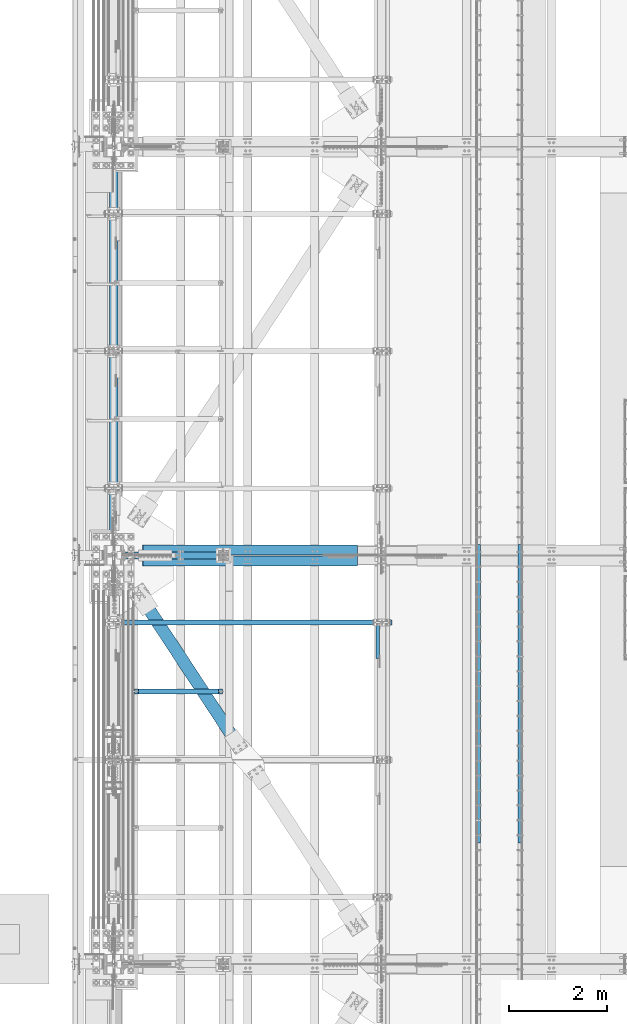
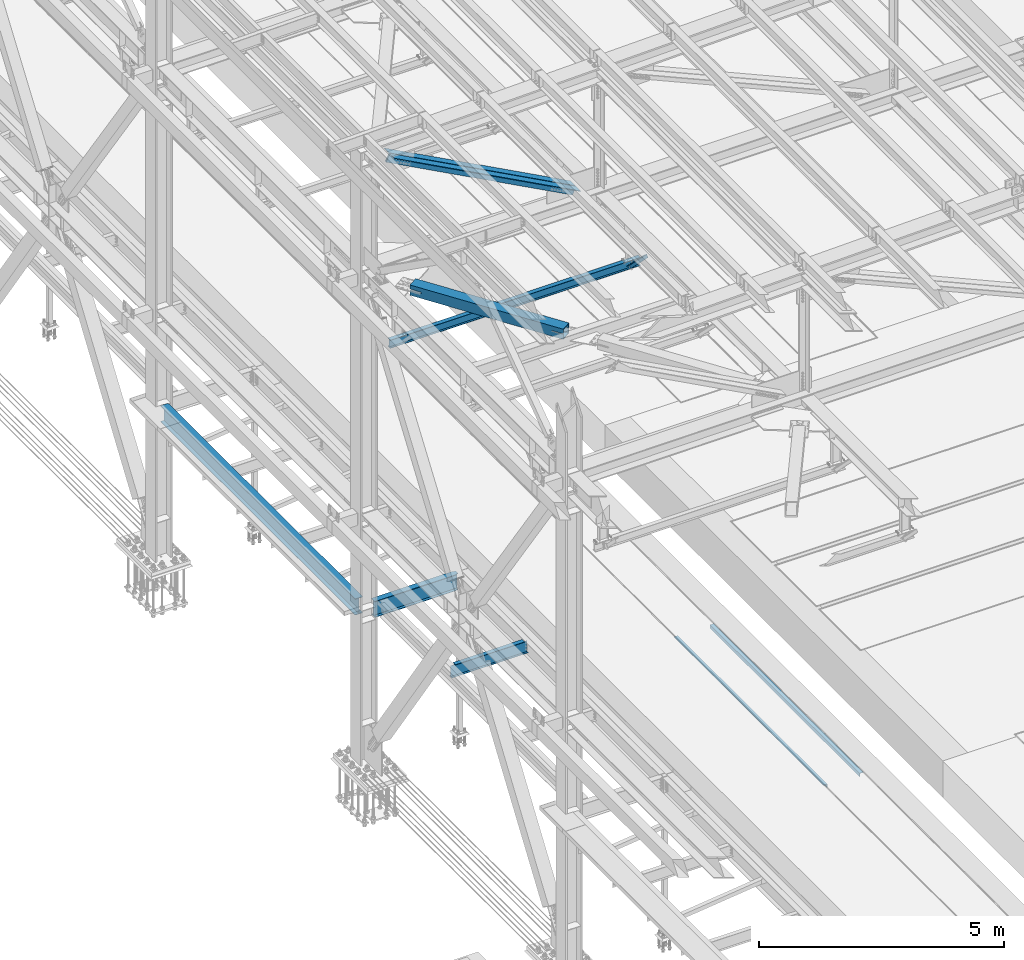
# One storey, part 1819 of 3843: 7 beams, 3 members, 10 elements without a shape of their own.
"""IFC2X3 building model written with IfcOpenShell, lengths in millimetres."""

from ifc_helpers import new_model, si_unit, frame, origin_with_axes, place, context, subcontext, project, spatial, faceted_brep, material, type_object, element, aggregate, save


model = new_model("IFC2X3")

# Units and contexts
model_context = context("Model", 3, precision=1e-05, world=origin_with_axes())
body_context = subcontext(model_context, "Body", "Model", "MODEL_VIEW")
ifc_project = project(units=[si_unit("LENGTHUNIT", "METRE", prefix="MILLI"), si_unit("AREAUNIT", "SQUARE_METRE"), si_unit("VOLUMEUNIT", "CUBIC_METRE"), si_unit("MASSUNIT", "GRAM", prefix="KILO"), si_unit("TIMEUNIT", "SECOND"), si_unit("PLANEANGLEUNIT", "RADIAN"), si_unit("SOLIDANGLEUNIT", "STERADIAN"), si_unit("THERMODYNAMICTEMPERATUREUNIT", "DEGREE_CELSIUS"), si_unit("LUMINOUSINTENSITYUNIT", "LUMEN")], contexts=[model_context])

# Site, building, storey
site_placement = place(None, origin_with_axes())
site = spatial("IfcSite", under=ifc_project, at=site_placement, CompositionType="ELEMENT")
building_placement = place(site_placement, origin_with_axes())
building = spatial("IfcBuilding", under=site, at=building_placement, Name="Undefined", CompositionType="ELEMENT")
storey_placement = place(building_placement, origin_with_axes())
storey = spatial("IfcBuildingStorey", under=building, at=storey_placement, Name="Undefined", CompositionType="ELEMENT", Elevation=0.0)

# Assembly, beam
assembly_1_placement = place(storey_placement, origin_with_axes())
assembly_1 = element("IfcElementAssembly", 1, at=assembly_1_placement, inside=storey, Name="EMBED_ANGLE", AssemblyPlace="NOTDEFINED", PredefinedType="RIGID_FRAME")
ifc_material_1 = material(Name="STEEL/A36")
beam_type_1 = type_object("IfcBeamType", Name="L3-1/2X3-1/2X5/16", PredefinedType="NOTDEFINED")
beam_1_placement = place(assembly_1_placement, frame((44887.896, 59134.375, 30419.675), z_axis=(0.0, 0.0, -1.0), x_axis=(0.0, -1.0, 0.0)))
beam_1 = element("IfcBeam", 2, at=beam_1_placement, type_object=beam_type_1, material=ifc_material_1, Name="EMBED_ANGLE", ObjectType="L3-1/2X3-1/2X5/16", context=body_context, shape_type="Brep", body=[
    faceted_brep([(-3.63797880709171e-12, 44.4499999999971, -44.4500000000007), (-3.63797880709171e-12, 44.4499999999971, 44.4500000000007), (6096.0, 44.4499999999971, 44.4500000000007), (6096.0, 44.4499999999971, -44.4500000000007), (-3.63797880709171e-12, 36.5124999999971, 44.4500000000007), (6096.0, 36.5124999999971, 44.4500000000007), (-3.63797880709171e-12, 36.5124999999971, -36.5125000000007), (6096.0, 36.5124999999971, -36.5125000000007), (3.63797880709171e-12, -44.4499999999971, -36.5125000000007), (6096.0, -44.4499999999971, -36.5125000000007), (3.63797880709171e-12, -44.4499999999971, -44.4500000000007), (6096.0, -44.4499999999971, -44.4500000000007)], [[[0, 1, 2, 3]], [[1, 4, 5, 2]], [[4, 6, 7, 5]], [[6, 8, 9, 7]], [[8, 10, 11, 9]], [[10, 0, 3, 11]], [[5, 7, 9, 11, 3, 2]], [[10, 8, 6, 4, 1, 0]]]),
])
aggregate(assembly_1, [beam_1])

assembly_2_placement = place(storey_placement, origin_with_axes())
assembly_2 = element("IfcElementAssembly", 3, at=assembly_2_placement, inside=storey, Name="EMBED_ANGLE", AssemblyPlace="NOTDEFINED", PredefinedType="RIGID_FRAME")
beam_2_placement = place(assembly_2_placement, frame((44036.996, 53038.375, 30419.675), z_axis=(0.0, 0.0, -1.0), x_axis=(0.0, 1.0, 0.0)))
beam_2 = element("IfcBeam", 4, at=beam_2_placement, type_object=beam_type_1, material=ifc_material_1, Name="EMBED_ANGLE", ObjectType="L3-1/2X3-1/2X5/16", context=body_context, shape_type="Brep", body=[
    faceted_brep([(-3.63797880709171e-12, 44.4499999999971, -44.4500000000007), (-3.63797880709171e-12, 44.4499999999971, 44.4500000000007), (6096.0, 44.4499999999971, 44.4500000000007), (6096.0, 44.4499999999971, -44.4500000000007), (-3.63797880709171e-12, 36.5124999999971, 44.4500000000007), (6096.0, 36.5124999999971, 44.4500000000007), (-3.63797880709171e-12, 36.5124999999971, -36.5125000000007), (6096.0, 36.5124999999971, -36.5125000000007), (3.63797880709171e-12, -44.4499999999971, -36.5125000000007), (6096.0, -44.4499999999971, -36.5125000000007), (3.63797880709171e-12, -44.4499999999971, -44.4500000000007), (6096.0, -44.4499999999971, -44.4500000000007)], [[[0, 1, 2, 3]], [[1, 4, 5, 2]], [[4, 6, 7, 5]], [[6, 8, 9, 7]], [[8, 10, 11, 9]], [[10, 0, 3, 11]], [[5, 7, 9, 11, 3, 2]], [[10, 8, 6, 4, 1, 0]]]),
])
aggregate(assembly_2, [beam_2])

# Assembly, member
assembly_3_placement = place(storey_placement, origin_with_axes())
assembly_3 = element("IfcElementAssembly", 5, at=assembly_3_placement, inside=storey, Name="ANGLE", AssemblyPlace="NOTDEFINED", PredefinedType="RIGID_FRAME")
ifc_material_2 = material(Name="STEEL/A572-50")
member_type_1 = type_object("IfcMemberType", Name="L3X3X1/4", PredefinedType="NOTDEFINED")
member_1_placement = place(assembly_3_placement, frame((41973.5, 56532.0689186757, 42312.0310813243), z_axis=(0.0, -0.707106781186548, -0.707106781186548), x_axis=(5.70000238222118e-08, 0.707106781186546, -0.707106781186546)))
member_1 = element("IfcMember", 6, at=member_1_placement, type_object=member_type_1, material=ifc_material_2, Name="ANGLE", ObjectType="L3X3X1/4", context=body_context, shape_type="Brep", body=[
    faceted_brep([(1347.66111465942, -38.0999999999985, -31.7499999999272), (1347.66111465942, -38.0999999999985, -38.099999999904), (1347.66111465942, 38.0999999999985, -38.099999999904), (1347.66111465941, 38.0999999999985, 38.0999999999185), (1347.66111465941, 31.75, 38.0999999999185), (1347.66111465942, 31.75, -31.7499999999272), (357.061114659338, 31.75, 38.0999999999185), (357.061114659338, 31.75, -31.7499999999127), (357.061114659338, -38.0999999999985, -31.7499999999127), (357.061114659338, -38.0999999999985, -38.099999999904), (357.061114659338, 38.0999999999985, -38.099999999904), (357.061114659338, 38.0999999999985, 38.0999999999185)], [[[0, 1, 2, 3, 4, 5]], [[5, 4, 6, 7]], [[0, 5, 7, 8]], [[1, 0, 8, 9]], [[2, 1, 9, 10]], [[3, 2, 10, 11]], [[4, 3, 11, 6]], [[10, 9, 8, 7, 6, 11]]]),
])
aggregate(assembly_3, [member_1])

# Assembly, beam
assembly_4_placement = place(storey_placement, origin_with_axes())
assembly_4 = element("IfcElementAssembly", 7, at=assembly_4_placement, inside=storey, Name="BEAM", AssemblyPlace="NOTDEFINED", PredefinedType="RIGID_FRAME")
ifc_material_3 = material(Name="STEEL/A992")
beam_type_2 = type_object("IfcBeamType", Name="W8X13", PredefinedType="NOTDEFINED")
beam_3_placement = place(assembly_4_placement, frame((36372.8, 57543.7, 41402.0), z_axis=(0.0, 0.0, 1.0), x_axis=(1.0, 0.0, 0.0)))
beam_3 = element("IfcBeam", 8, at=beam_3_placement, type_object=beam_type_2, material=ifc_material_3, Name="BEAM", ObjectType="W8X13", context=body_context, shape_type="Brep", body=[
    faceted_brep([(0.0, 50.7999999999993, -101.599999999999), (0.0, 50.7999999999993, -95.25), (5892.8, 50.7999999999993, -95.25), (5892.8, 50.7999999999993, -101.599999999999), (0.0, 3.17499999999927, -95.25), (5892.8, 3.17499999999927, -95.25), (-2.44140610448085e-05, 3.17500000000291, 95.2499999999927), (5892.8, 3.17499999999927, 95.25), (0.0, 50.7999999999993, 95.25), (5892.8, 50.7999999999993, 95.25), (0.0, 50.7999999999993, 101.599999999999), (5892.8, 50.7999999999993, 101.599999999999), (0.0, -50.7999999999993, 101.599999999999), (5892.8, -50.7999999999993, 101.599999999999), (0.0, -50.7999999999993, 95.25), (5892.8, -50.7999999999993, 95.25), (0.0, -3.17499999999927, 95.25), (5892.8, -3.17499999999927, 95.25), (0.0, -3.17499999999927, -95.25), (5892.8, -3.17499999999927, -95.25), (0.0, -50.7999999999993, -95.25), (5892.8, -50.7999999999993, -95.25), (0.0, -50.7999999999993, -101.599999999999), (5892.8, -50.7999999999993, -101.599999999999)], [[[0, 1, 2, 3]], [[1, 4, 5, 2]], [[4, 6, 7, 5]], [[6, 8, 9, 7]], [[8, 10, 11, 9]], [[10, 12, 13, 11]], [[12, 14, 15, 13]], [[14, 16, 17, 15]], [[16, 18, 19, 17]], [[18, 20, 21, 19]], [[20, 22, 23, 21]], [[22, 0, 3, 23]], [[5, 7, 9, 11, 13, 15, 17, 19, 21, 23, 3, 2]], [[22, 20, 18, 16, 14, 12, 10, 8, 6, 4, 1, 0]]]),
])
aggregate(assembly_4, [beam_3])

# Assembly, member
assembly_5_placement = place(storey_placement, origin_with_axes())
assembly_5 = element("IfcElementAssembly", 9, at=assembly_5_placement, inside=storey, Name="ANGLE", AssemblyPlace="NOTDEFINED", PredefinedType="RIGID_FRAME")
member_type_2 = type_object("IfcMemberType", Name="L8X8X1/2", PredefinedType="NOTDEFINED")
member_2_placement = place(assembly_5_placement, frame((36576.0, 59026.425, 45221.4518084381), z_axis=(-0.472785194825838, 0.0, -0.8811777116754), x_axis=(0.8811777116754, 0.0, -0.472785194825839)))
member_2 = element("IfcMember", 10, at=member_2_placement, type_object=member_type_2, material=ifc_material_2, Name="ANGLE", ObjectType="L8X8X1/2", context=body_context, shape_type="Brep", body=[
    faceted_brep([(625.176479064765, 101.599999999999, -101.600000001054), (625.176479064772, 101.599999999999, 101.599999999627), (5601.4263412947, 101.599999999999, 101.599999993981), (5601.42634129471, 101.599999999999, -101.600000006707), (625.176479064772, 88.9000000000015, 101.599999999627), (5601.4263412947, 88.9000000000015, 101.599999993981), (625.176479064769, 88.9000000000015, -88.9000000010128), (5601.42634129471, 88.9000000000015, -88.9000000066735), (625.176479064769, -101.599999999999, -88.9000000010128), (5601.42634129471, -101.599999999999, -88.9000000066735), (625.176479064765, -101.599999999999, -101.600000001054), (5601.42634129471, -101.599999999999, -101.600000006707)], [[[0, 1, 2, 3]], [[1, 4, 5, 2]], [[4, 6, 7, 5]], [[6, 8, 9, 7]], [[8, 10, 11, 9]], [[10, 0, 3, 11]], [[5, 7, 9, 11, 3, 2]], [[10, 8, 6, 4, 1, 0]]]),
])
aggregate(assembly_5, [member_2])

assembly_6_placement = place(storey_placement, origin_with_axes())
assembly_6 = element("IfcElementAssembly", 11, at=assembly_6_placement, inside=storey, Name="ANGLE", AssemblyPlace="NOTDEFINED", PredefinedType="RIGID_FRAME")
member_3_placement = place(assembly_6_placement, frame((42062.3999992073, 58804.175, 42277.790551132), z_axis=(-0.472785194825838, 0.0, -0.8811777116754), x_axis=(-0.8811777116754, 0.0, 0.472785194825838)))
member_3 = element("IfcMember", 12, at=member_3_placement, type_object=member_type_2, material=ifc_material_2, Name="ANGLE", ObjectType="L8X8X1/2", context=body_context, shape_type="Brep", body=[
    faceted_brep([(624.786516421329, 101.599999999999, -101.599999999627), (624.786516421325, 101.599999999999, 101.600000001054), (5601.03637865126, 101.599999999999, 101.600000006707), (5601.03637865126, 101.599999999999, -101.599999993981), (624.786516421325, 88.9000000000015, 101.600000001054), (5601.03637865126, 88.9000000000015, 101.600000006707), (624.786516421325, 88.9000000000015, -88.899999999594), (5601.03637865126, 88.9000000000015, -88.8999999939406), (624.786516421325, -101.599999999999, -88.899999999594), (5601.03637865126, -101.599999999999, -88.8999999939406), (624.786516421329, -101.599999999999, -101.599999999627), (5601.03637865126, -101.599999999999, -101.599999993981)], [[[0, 1, 2, 3]], [[1, 4, 5, 2]], [[4, 6, 7, 5]], [[6, 8, 9, 7]], [[8, 10, 11, 9]], [[10, 0, 3, 11]], [[5, 7, 9, 11, 3, 2]], [[10, 8, 6, 4, 1, 0]]]),
])
aggregate(assembly_6, [member_3])

# Assembly, beam
assembly_7_placement = place(storey_placement, origin_with_axes())
assembly_7 = element("IfcElementAssembly", 13, at=assembly_7_placement, inside=storey, AssemblyPlace="NOTDEFINED", PredefinedType="RIGID_FRAME")
ifc_material_4 = material()
beam_type_3 = type_object("IfcBeamType", Name="HSS10X10X3/4", PredefinedType="NOTDEFINED")
beam_4_placement = place(assembly_7_placement, frame((36576.0, 58915.3, 42246.55), z_axis=(0.835938629021657, 0.548822930014219, 0.0), x_axis=(0.548822930014218, -0.835938629021658, 0.0)))
beam_4 = element("IfcBeam", 14, at=beam_4_placement, type_object=beam_type_3, material=ifc_material_4, ObjectType="HSS10X10X3/4", context=body_context, shape_type="Brep", body=[
    faceted_brep([(4607.8393605934, 1.58750000000146, 127.000000003842), (4355.42686058164, 1.58750000000146, 127.000000003667), (4355.42686058166, 1.58750000000146, 107.950000003577), (4607.83936059341, 1.58750000000146, 107.950000003759), (4352.38931083721, 0.983293789307936, 127.000000003667), (4352.38931083722, 0.983293789307936, 107.950000003577), (4349.8142005059, -0.737339924329717, 127.00000000366), (4349.81420050591, -0.737339924329717, 107.950000003577), (4348.09356679223, -3.31245025560202, 127.00000000366), (4348.09356679225, -3.31245025560202, 107.95000000357), (4347.48936058155, -6.34999999999854, 127.000000003653), (4347.48936058156, -6.34999999999854, 107.950000003577), (4348.09356679223, -9.38754974439507, 127.00000000366), (4348.09356679225, -9.38754974439507, 107.95000000357), (4349.8142005059, -11.9626600756674, 127.00000000366), (4349.81420050591, -11.9626600756674, 107.950000003577), (4352.38931083721, -13.683293789305, 127.000000003667), (4352.38931083722, -13.683293789305, 107.950000003577), (4355.42686058164, -14.2874999999985, 127.000000003667), (4355.42686058166, -14.2874999999985, 107.950000003577), (4607.8393605934, -14.2874999999985, 127.000000003842), (4607.83936059341, -14.2874999999985, 107.950000003759), (4607.83936059341, 1.58750000000146, -107.949999997174), (4355.42686058181, 1.58750000000146, -107.949999997363), (4355.42686058182, 1.58750000000146, -126.999999997439), (4607.83936059341, 1.58750000000146, -126.999999997264), (4352.38931083737, 0.983293789307936, -107.949999997356), (4352.38931083739, 0.983293789307936, -126.999999997439), (4349.81420050607, -0.737339924329717, -107.949999997363), (4349.81420050608, -0.737339924329717, -126.999999997439), (4348.0935667924, -3.31245025560202, -107.949999997363), (4348.09356679242, -3.31245025560202, -126.999999997439), (4347.48936058171, -6.34999999999854, -107.949999997363), (4347.48936058172, -6.34999999999854, -126.999999997453), (4348.0935667924, -9.38754974439507, -107.949999997363), (4348.09356679242, -9.38754974439507, -126.999999997439), (4349.81420050607, -11.9626600756674, -107.949999997363), (4349.81420050608, -11.9626600756674, -126.999999997439), (4352.38931083737, -13.683293789305, -107.949999997356), (4352.38931083739, -13.683293789305, -126.999999997439), (4355.42686058181, -14.2874999999985, -107.949999997363), (4355.42686058182, -14.2874999999985, -126.999999997439), (4607.83936059341, -14.2874999999985, -107.949999997174), (4607.83936059341, -14.2874999999985, -126.999999997264), (1109.41820844431, 107.949999999997, 107.95000000127), (1109.41820844432, 107.949999999997, -107.949999999662), (4607.83936059341, 107.949999999997, -107.949999997174), (4607.83936059341, 107.949999999997, 107.950000003759), (4607.83936059341, -107.949999999997, 107.950000003759), (1109.41820844431, -107.949999999997, 107.95000000127), (1109.41820844431, -26.9875000002503, 107.95000000127), (1361.83070807912, -26.9875000002503, 107.950000001452), (1367.29829776509, -25.8999287919651, 107.950000001452), (1371.9334964852, -22.8027880247246, 107.95000000146), (1375.03063725248, -18.1675893046777, 107.950000001452), (1376.11820846077, -12.6999996187806, 107.95000000146), (1375.03063725248, -7.23241069582582, 107.950000001452), (1371.9334964852, -2.59721197577892, 107.95000000146), (1367.29829776509, 0.499928791461571, 107.950000001452), (1361.83070807912, 1.5874999997468, 107.950000001452), (1109.41820844431, 1.5874999997468, 107.95000000127), (1109.41820844432, -107.949999999997, -107.949999999662), (4607.83936059341, -107.949999999997, -107.949999997174), (1109.41820844432, 1.5874999997468, -107.949999999662), (1361.83070807928, 1.5874999997468, -107.949999999488), (1367.29829776525, 0.499928791461571, -107.949999999488), (1371.93349648534, -2.59721197577892, -107.949999999473), (1375.03063725263, -7.23241069582582, -107.94999999948), (1376.11820846093, -12.6999996187806, -107.949999999473), (1375.03063725263, -18.1675893046777, -107.94999999948), (1371.93349648534, -22.8027880247246, -107.949999999473), (1367.29829776525, -25.8999287919651, -107.949999999488), (1361.83070807928, -26.9875000002503, -107.949999999488), (1109.41820844432, -26.9875000002503, -107.949999999662), (1109.41820844431, 1.5874999997468, -126.999999999753), (1361.83070807929, 1.5874999997468, -126.999999999571), (1367.29829776526, 0.499928791461571, -126.999999999563), (1371.93349648536, -2.59721197577892, -126.999999999563), (1375.03063725264, -7.23241069582582, -126.999999999563), (1376.11820846094, -12.6999996187806, -126.999999999563), (1375.03063725264, -18.1675893046777, -126.999999999563), (1371.93349648536, -22.8027880247246, -126.999999999563), (1367.29829776526, -25.8999287919651, -126.999999999563), (1361.83070807929, -26.9875000002503, -126.999999999571), (1109.41820844431, -26.9875000002503, -126.999999999753), (1109.41820844431, -127.0, -126.999999999753), (1109.41820844431, -127.0, 127.000000001353), (1109.41820844431, -26.9875000002503, 127.000000001353), (1361.83070807911, -26.9875000002503, 127.000000001528), (1367.29829776508, -25.8999287919651, 127.000000001543), (1371.93349648518, -22.8027880247246, 127.000000001543), (1375.03063725246, -18.1675893046777, 127.000000001543), (1376.11820846076, -12.6999996187806, 127.000000001543), (1375.03063725246, -7.23241069582582, 127.000000001543), (1371.93349648518, -2.59721197577892, 127.000000001543), (1367.29829776508, 0.499928791461571, 127.000000001543), (1361.83070807911, 1.5874999997468, 127.000000001528), (1109.41820844431, 1.5874999997468, 127.000000001353), (1109.41820844431, 127.0, 127.000000001353), (1109.41820844431, 127.0, -126.999999999753), (4607.8393605934, 127.0, 127.000000003842), (4607.83936059341, 127.0, -126.999999997264), (4607.83936059341, -127.0, -126.999999997264), (4607.8393605934, -127.0, 127.000000003842)], [[[0, 1, 2, 3]], [[4, 5, 2, 1]], [[6, 7, 5, 4]], [[8, 9, 7, 6]], [[10, 11, 9, 8]], [[12, 13, 11, 10]], [[14, 15, 13, 12]], [[16, 17, 15, 14]], [[18, 19, 17, 16]], [[20, 21, 19, 18]], [[22, 23, 24, 25]], [[26, 27, 24, 23]], [[28, 29, 27, 26]], [[30, 31, 29, 28]], [[32, 33, 31, 30]], [[34, 35, 33, 32]], [[36, 37, 35, 34]], [[38, 39, 37, 36]], [[40, 41, 39, 38]], [[42, 43, 41, 40]], [[44, 45, 46, 47]], [[48, 49, 50, 51, 52, 53, 54, 55, 56, 57, 58, 59, 60, 44, 47, 3, 2, 5, 7, 9, 11, 13, 15, 17, 19, 21]], [[61, 49, 48, 62]], [[38, 36, 34, 32, 30, 28, 26, 23, 22, 46, 45, 63, 64, 65, 66, 67, 68, 69, 70, 71, 72, 73, 61, 62, 42, 40]], [[63, 74, 75, 64]], [[64, 75, 76, 65]], [[65, 76, 77, 66]], [[66, 77, 78, 67]], [[67, 78, 79, 68]], [[68, 79, 80, 69]], [[69, 80, 81, 70]], [[70, 81, 82, 71]], [[71, 82, 83, 72]], [[72, 83, 84, 73]], [[49, 61, 73, 84, 85, 86, 87, 50]], [[88, 51, 50, 87]], [[89, 52, 51, 88]], [[90, 53, 52, 89]], [[91, 54, 53, 90]], [[92, 55, 54, 91]], [[93, 56, 55, 92]], [[94, 57, 56, 93]], [[95, 58, 57, 94]], [[96, 59, 58, 95]], [[97, 60, 59, 96]], [[98, 99, 74, 63, 45, 44, 60, 97]], [[99, 98, 100, 101]], [[47, 46, 22, 25, 101, 100, 0, 3]], [[102, 85, 84, 83, 82, 81, 80, 79, 78, 77, 76, 75, 74, 99, 101, 25, 24, 27, 29, 31, 33, 35, 37, 39, 41, 43]], [[86, 85, 102, 103]], [[16, 14, 12, 10, 8, 6, 4, 1, 0, 100, 98, 97, 96, 95, 94, 93, 92, 91, 90, 89, 88, 87, 86, 103, 20, 18]], [[103, 102, 43, 42, 62, 48, 21, 20]]]),
])
aggregate(assembly_7, [beam_4])

assembly_8_placement = place(storey_placement, origin_with_axes())
assembly_8 = element("IfcElementAssembly", 15, at=assembly_8_placement, inside=storey, Name="BEAM", AssemblyPlace="NOTDEFINED", PredefinedType="RIGID_FRAME")
beam_type_4 = type_object("IfcBeamType", Name="W16X40", PredefinedType="NOTDEFINED")
beam_5_placement = place(assembly_8_placement, frame((36576.0, 58915.3, 33832.8), z_axis=(0.0, 0.0, 1.0), x_axis=(0.0, 1.0, 0.0)))
beam_5 = element("IfcBeam", 16, at=beam_5_placement, type_object=beam_type_4, material=ifc_material_3, Name="BEAM", ObjectType="W16X40", context=body_context, shape_type="Brep", body=[
    faceted_brep([(212.724999999991, -88.9000000000015, -203.199999999997), (212.724999999991, 88.9000000000015, -203.199999999997), (8143.87499999999, 88.9000000000015, -203.199999999997), (8143.87499999999, -88.9000000000015, -203.199999999997), (212.724999999991, -88.9000000000015, -190.5), (212.724999999991, -3.96875, -190.5), (212.724999999991, -3.96875, -140.440014362968), (212.724999999991, -3.96875, 165.839999999997), (212.724999999991, -3.96875, 190.5), (212.724999999991, -88.9000000000015, 190.5), (212.724999999991, -88.9000000000015, 203.199999999997), (212.724999999991, 88.9000000000015, 203.199999999997), (212.724999999991, 88.9000000000015, 190.5), (212.724999999991, 3.96875, 190.5), (212.724999999991, 3.96875, -190.5), (212.724999999991, 88.9000000000015, -190.5), (8143.87499999999, -88.9000000000015, -190.5), (8143.87499999999, -3.96875, -190.5), (8143.87499999999, -3.96875, -140.440014362968), (8143.87499999999, -3.96875, 165.839999999997), (8143.87499999999, -3.96875, 190.5), (8143.87499999999, -88.9000000000015, 190.5), (8143.87499999999, -88.9000000000015, 203.199999999997), (8143.87499999999, 88.9000000000015, 203.199999999997), (8143.87499999999, 88.9000000000015, 190.5), (8143.87499999999, 3.96875, 190.5), (8143.87499999999, 3.96875, -190.5), (8143.87499999999, 88.9000000000015, -190.5)], [[[0, 1, 2, 3]], [[0, 4, 5, 6, 7, 8, 9, 10, 11, 12, 13, 14, 15, 1]], [[5, 4, 16, 17]], [[8, 7, 6, 5, 17, 18, 19, 20]], [[9, 8, 20, 21]], [[10, 9, 21, 22]], [[11, 10, 22, 23]], [[12, 11, 23, 24]], [[13, 12, 24, 25]], [[14, 13, 25, 26]], [[15, 14, 26, 27]], [[1, 15, 27, 2]], [[26, 25, 24, 23, 22, 21, 20, 19, 18, 17, 16, 3, 2, 27]], [[4, 0, 3, 16]]]),
])
aggregate(assembly_8, [beam_5])

assembly_9_placement = place(storey_placement, origin_with_axes())
assembly_9 = element("IfcElementAssembly", 17, at=assembly_9_placement, inside=storey, Name="BEAM", AssemblyPlace="NOTDEFINED", PredefinedType="RIGID_FRAME")
beam_type_5 = type_object("IfcBeamType", Name="W16X26", PredefinedType="NOTDEFINED")
beam_6_placement = place(assembly_9_placement, frame((36576.0, 58915.3, 33835.975), z_axis=(0.0, 0.0, 1.0), x_axis=(1.0, 0.0, 0.0)))
beam_6 = element("IfcBeam", 18, at=beam_6_placement, type_object=beam_type_5, material=ifc_material_3, Name="BEAM", ObjectType="W16X26", context=body_context, shape_type="Brep", body=[
    faceted_brep([(2130.42500076294, 50.8000007629307, 200.025000000016), (2130.42500076294, 50.8000007629307, 190.5), (2130.42500076294, 69.8500000000058, 190.5), (2130.42500076294, 69.8500000000058, 200.025000000001), (2181.22500000001, 50.8000007629307, 200.025000000016), (2181.225, 50.8000007629307, 190.5), (2130.42500076294, 50.8000007629307, -190.5), (2130.42500076294, 50.8000007629307, -200.025000000001), (2130.42500076294, 69.8500000000058, -200.025000000001), (2130.42500076294, 69.8500000000058, -190.5), (2181.22500000001, 50.8000007629307, -190.5), (2181.225, 50.8000007629307, -200.025000000001), (2130.42500076294, -69.8500000000058, -190.5), (2130.42500076294, -69.8500000000058, -200.025000000001), (2130.42500076294, -50.8000007629307, -200.025000000001), (2130.42500076294, -50.8000007629307, -190.5), (212.724999999999, -69.8500000000058, -190.5), (212.724999999999, -69.8500000000058, -200.025000000001), (2130.42500076294, -69.8500000000058, 200.025000000001), (2130.42500076294, -69.8500000000058, 190.5), (2130.42500076294, -50.8000007629307, 190.5), (2130.42500076294, -50.8000007629307, 200.025000000016), (212.724999999999, -69.8500000000058, 200.025000000001), (212.724999999999, -69.8500000000058, 190.5), (212.724999999999, -3.17500000000291, -190.5), (212.724999999999, -3.17500000000291, 190.5), (212.724999999999, 69.8500000000058, 200.025000000001), (212.724999999999, 69.8500000000058, 190.5), (212.724999999999, 3.17500000000291, 190.5), (212.724999999999, 3.17500000000291, -190.5), (212.724999999999, 69.8500000000058, -190.5), (212.724999999999, 69.8500000000058, -200.025000000001), (2181.225, 3.17500000000291, 190.5), (2181.225, 3.17500000000291, -190.5), (2181.225, -50.8000007629307, -200.025000000001), (2181.22500000001, -50.8000007629307, -190.5), (2181.225, -3.17500000000291, -190.5), (2181.225, -3.17500000000291, 190.5), (2181.225, -50.8000007629307, 190.5), (2181.22500000001, -50.8000007629307, 200.025000000016)], [[[0, 1, 2, 3]], [[4, 5, 1, 0]], [[6, 7, 8, 9]], [[10, 11, 7, 6]], [[12, 13, 14, 15]], [[16, 17, 13, 12]], [[18, 19, 20, 21]], [[22, 23, 19, 18]], [[17, 16, 24, 25, 23, 22, 26, 27, 28, 29, 30, 31]], [[27, 26, 3, 2]], [[32, 28, 27, 2, 1, 5]], [[29, 28, 32, 33]], [[9, 30, 29, 33, 10, 6]], [[31, 30, 9, 8]], [[34, 14, 13, 17, 31, 8, 7, 11]], [[35, 15, 14, 34]], [[36, 24, 16, 12, 15, 35]], [[25, 24, 36, 37]], [[19, 23, 25, 37, 38, 20]], [[39, 21, 20, 38]], [[3, 26, 22, 18, 21, 39, 4, 0]], [[39, 38, 37, 36, 35, 34, 11, 10, 33, 32, 5, 4]]]),
])
aggregate(assembly_9, [beam_6])

assembly_10_placement = place(storey_placement, origin_with_axes())
assembly_10 = element("IfcElementAssembly", 19, at=assembly_10_placement, inside=storey, Name="BEAM", AssemblyPlace="NOTDEFINED", PredefinedType="RIGID_FRAME")
beam_type_6 = type_object("IfcBeamType", Name="W12X14", PredefinedType="NOTDEFINED")
beam_7_placement = place(assembly_10_placement, frame((36982.4, 56129.634376, 33885.1875), z_axis=(0.0, 0.0, 1.0), x_axis=(1.0, 0.0, 0.0)))
beam_7 = element("IfcBeam", 20, at=beam_7_placement, type_object=beam_type_6, material=ifc_material_3, Name="BEAM", ObjectType="W12X14", context=body_context, shape_type="Brep", body=[
    faceted_brep([(92.8687501907334, -2.38125000000582, 125.412499999991), (92.8687501907334, 2.38125000000582, 125.412499999991), (16.6687499999971, 2.38125000000582, 125.412499999991), (16.6687499999971, -2.38125000000582, 125.412499999991), (97.7288297087798, -2.38125000000582, 126.379229922582), (97.7288297087798, 2.38125000000582, 126.379229922582), (101.849006176933, -2.38125000000582, 129.132243823056), (101.849006176933, 2.38125000000582, 129.132243823056), (104.602020077407, -2.38125000000582, 133.25242029121), (104.602020077407, 2.38125000000582, 133.25242029121), (105.568749999999, -2.38125000000582, 138.112499809256), (105.568749999999, 2.38125000000582, 138.112499809256), (105.568749999999, -50.8000000000029, 150.812499810811), (105.568749999999, 50.8000000000029, 150.8125), (105.568749999999, 50.8000000000029, 144.462500000001), (105.568749999999, 2.38125000000582, 144.462500000001), (105.568749999999, -2.38125000000582, 144.462500000001), (105.568749999999, -50.8000000000029, 144.462500000001), (16.6687499999971, -2.38125000000582, -144.462500000001), (16.6687499999971, -50.7999999999993, -144.462500000001), (1821.65625, -50.8000000000029, -144.462500000001), (1821.65625, -2.38125000000582, -144.462500000001), (16.6687499999971, -50.8000000000029, -150.8125), (1821.65625, -50.8000000000029, -150.8125), (16.6687499999971, 50.8000000000029, -150.8125), (1821.65625, 50.8000000000029, -150.8125), (16.6687499999971, 50.7999999999993, -144.462500000001), (1821.65625, 50.8000000000029, -144.462500000001), (16.6687499999971, 2.38125000000582, -144.462500000001), (1821.65625, 2.38125000000582, -144.462500000001), (1821.65625, 2.38125000000582, -117.887499999997), (1821.65625, 2.38125000000582, 112.712500000001), (1821.65625, 2.38125000000582, 125.412499999991), (1821.65625, -2.38125000000582, 125.412499999991), (1745.45624980926, 2.38125000000582, 125.412499999991), (1745.45624980926, -2.38125000000582, 125.412499999991), (1740.59617029122, 2.38125000000582, 126.379229922582), (1740.59617029122, -2.38125000000582, 126.379229922582), (1736.47599382306, 2.38125000000582, 129.132243823056), (1736.47599382306, -2.38125000000582, 129.132243823056), (1733.72297992259, 2.38125000000582, 133.25242029121), (1733.72297992259, -2.38125000000582, 133.25242029121), (1732.75625, 2.38125000000582, 138.112499809256), (1732.75625, -2.38125000000582, 138.112499809256), (1732.75625, -50.8000000000029, 150.8125), (1732.75625, -50.8000000000029, 144.462500000001), (1732.75625, -2.38125000000582, 144.462500000001), (1732.75625, 2.38125000000582, 144.462500000001), (1732.75625, 50.8000000000029, 144.462500000001), (1732.75625, 50.8000000000029, 150.8125), (16.6687499999971, 2.38125000000582, 112.712500000001), (16.6687499999971, 2.38125000000582, -117.887499999997)], [[[0, 1, 2, 3]], [[4, 5, 1, 0]], [[6, 7, 5, 4]], [[8, 9, 7, 6]], [[10, 11, 9, 8]], [[12, 13, 14, 15, 11, 10, 16, 17]], [[18, 19, 20, 21]], [[19, 22, 23, 20]], [[22, 24, 25, 23]], [[24, 26, 27, 25]], [[26, 28, 29, 27]], [[21, 20, 23, 25, 27, 29, 30, 31, 32, 33]], [[33, 32, 34, 35]], [[35, 34, 36, 37]], [[37, 36, 38, 39]], [[39, 38, 40, 41]], [[41, 40, 42, 43]], [[44, 45, 46, 43, 42, 47, 48, 49]], [[45, 44, 12, 17]], [[46, 45, 17, 16]], [[8, 6, 4, 0, 3, 18, 21, 33, 35, 37, 39, 41, 43, 46, 16, 10]], [[50, 51, 28, 26, 24, 22, 19, 18, 3, 2]], [[47, 42, 40, 38, 36, 34, 32, 31, 30, 29, 28, 51, 50, 2, 1, 5, 7, 9, 11, 15]], [[48, 47, 15, 14]], [[49, 48, 14, 13]], [[44, 49, 13, 12]]]),
])
aggregate(assembly_10, [beam_7])

save(model, "model.ifc")
